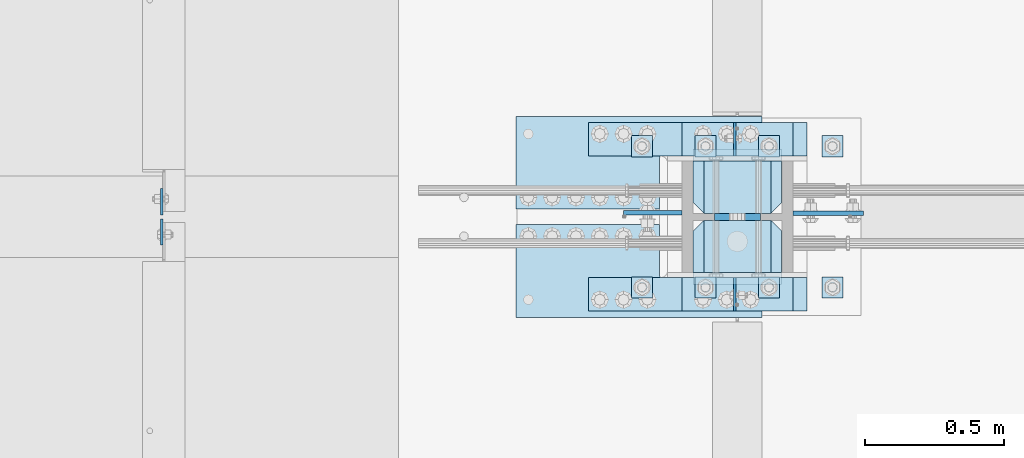
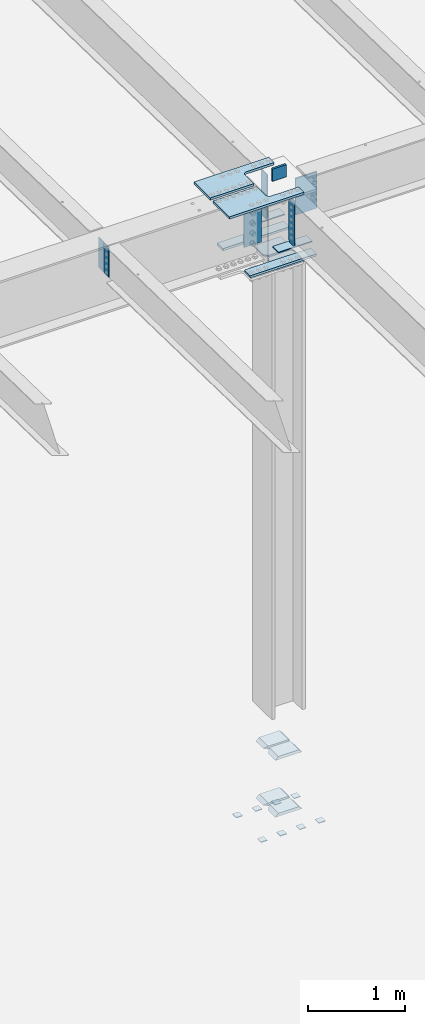
# One storey, part 1492 of 1763: 27 plates, 5 elements without a shape of their own.
"""IFC2X3 building model written with IfcOpenShell, lengths in millimetres."""

import ifcopenshell
import ifcopenshell.guid

model = None  # the IFC model being written
_history = None  # IfcOwnerHistory: only IFC2X3 demands one
_inside = {}  # id of a spatial element -> (the spatial element, [elements in it])
_under = {}  # id of a project, library or spatial element -> (it, [spatial elements below it])
_declared = {}  # id of a project -> (the project, [libraries it declares])
_typed = {}  # id of a type object -> (the type object, [elements of that type])
_made_of = {}  # id of a material, layer set ... -> (it, [elements and type objects made of it])


def new_model(schema):
    """Start an empty IFC model of exactly this schema.

    Asked for "IFC4X3", IfcOpenShell would pick the latest addendum, in which some entities
    have other attributes; the version numbers below select the first issue.
    IFC2X3 requires an IfcOwnerHistory on every rooted entity: one is made here for all.
    """
    global model, _history
    if schema == "IFC4X3":
        model = ifcopenshell.file(schema_version=(4, 3, 0, 0))
    else:
        model = ifcopenshell.file(schema=schema)
    _inside.clear()
    _under.clear()
    _declared.clear()
    _typed.clear()
    _made_of.clear()
    _history = None
    if model.schema == "IFC2X3":
        org = make("IfcOrganization", Name="unknown")
        user = make(
            "IfcPersonAndOrganization",
            ThePerson=make("IfcPerson", FamilyName="unknown"),
            TheOrganization=org,
        )
        app = make(
            "IfcApplication",
            ApplicationDeveloper=org,
            Version="unknown",
            ApplicationFullName="unknown",
            ApplicationIdentifier="unknown",
        )
        _history = make(
            "IfcOwnerHistory",
            OwningUser=user,
            OwningApplication=app,
            ChangeAction="ADDED",
            CreationDate=0,
        )
    return model


def make(cls, **values):
    """One entity of the class cls with the attributes given. An attribute that is None is left unset."""
    return model.create_entity(
        cls, **{name: value for name, value in values.items() if value is not None}
    )


def rooted(cls, **values):
    """An entity with a GlobalId (a new one), such as an element, a storey or a relation."""
    return make(cls, GlobalId=ifcopenshell.guid.new(), OwnerHistory=_history, **values)


def si_unit(unit_type, name, prefix=None):
    """IfcSIUnit, for example si_unit("LENGTHUNIT", "METRE", prefix="MILLI")."""
    return make("IfcSIUnit", UnitType=unit_type, Prefix=prefix, Name=name)


def assignment(units):
    """IfcUnitAssignment: the units of a project."""
    return None if units is None else make("IfcUnitAssignment", Units=units)


def point(xyz):
    """IfcCartesianPoint."""
    return None if xyz is None else make("IfcCartesianPoint", Coordinates=xyz)


def direction(xyz):
    """IfcDirection."""
    return None if xyz is None else make("IfcDirection", DirectionRatios=xyz)


def frame(location, z_axis=None, x_axis=None):
    """IfcAxis2Placement3D, a coordinate frame: its origin and axes. An axis left out is left unset."""
    return make(
        "IfcAxis2Placement3D",
        Location=point(location),
        Axis=direction(z_axis),
        RefDirection=direction(x_axis),
    )


def origin_with_axes():
    """The frame at (0, 0, 0) with the z axis (0, 0, 1) and the x axis (1, 0, 0) written out."""
    return frame((0.0, 0.0, 0.0), z_axis=(0.0, 0.0, 1.0), x_axis=(1.0, 0.0, 0.0))


def place(relative_to, where):
    """IfcLocalPlacement: puts the frame where relative to a parent placement (None: the world)."""
    return make(
        "IfcLocalPlacement", PlacementRelTo=relative_to, RelativePlacement=where
    )


def context(
    kind, dimensions, precision=None, world=None, true_north=None, identifier=None
):
    """IfcGeometricRepresentationContext, for example the 3D "Model" context."""
    return make(
        "IfcGeometricRepresentationContext",
        ContextIdentifier=identifier,
        ContextType=kind,
        CoordinateSpaceDimension=dimensions,
        Precision=precision,
        WorldCoordinateSystem=world,
        TrueNorth=true_north,
    )


def subcontext(parent, identifier, kind, view, scale=None):
    """IfcGeometricRepresentationSubContext, for example "Body" below "Model"."""
    return make(
        "IfcGeometricRepresentationSubContext",
        ContextIdentifier=identifier,
        ContextType=kind,
        ParentContext=parent,
        TargetScale=scale,
        TargetView=view,
    )


def project(units=None, contexts=None):
    """IfcProject with its units and contexts."""
    return rooted(
        "IfcProject",
        Name="project",
        RepresentationContexts=contexts,
        UnitsInContext=assignment(units),
    )


def spatial(cls, under=None, at=None, **own):
    """A site, building, storey or space (cls), placed at a placement, below another one or the project."""
    s = rooted(cls, ObjectPlacement=at, **own)
    if under is not None:
        _under.setdefault(under.id(), (under, []))[1].append(s)
    return s


def faces_of(points, faces, orient=None, outer=None):
    """IfcFace entities. A face is a list of loops; a loop is a list of indices into points, from 0.

    orient and outer hold one flag for each loop. By default every Orientation is true, the
    first loop of a face is its IfcFaceOuterBound and the others are IfcFaceBound.
    """
    made = []
    for i, loops in enumerate(faces):
        bounds = []
        for j, loop in enumerate(loops):
            is_outer = j == 0 if outer is None else outer[i][j]
            bounds.append(
                make(
                    "IfcFaceOuterBound" if is_outer else "IfcFaceBound",
                    Bound=make("IfcPolyLoop", Polygon=[points[k] for k in loop]),
                    Orientation=True if orient is None else orient[i][j],
                )
            )
        made.append(make("IfcFace", Bounds=bounds))
    return made


def faceted_brep(points, faces, orient=None, outer=None, voids=None):
    """IfcFacetedBrep: a solid bounded by flat faces; with voids (closed shells), ...WithVoids."""
    shared = [point(p) for p in points]
    hull = make("IfcClosedShell", CfsFaces=faces_of(shared, faces, orient, outer))
    if voids is None:
        return make("IfcFacetedBrep", Outer=hull)
    return make(
        "IfcFacetedBrepWithVoids",
        Outer=hull,
        Voids=[
            make(cls, CfsFaces=faces_of(shared, fs, o, b)) for cls, fs, o, b in voids
        ],
    )


def shape(context_of_items, identifier, shape_type, items):
    """IfcShapeRepresentation: the items that make up one representation, for example the "Body"."""
    return make(
        "IfcShapeRepresentation",
        ContextOfItems=context_of_items,
        RepresentationIdentifier=identifier,
        RepresentationType=shape_type,
        Items=items,
    )


def material(Name=None, Category=None):
    """IfcMaterial."""
    return make("IfcMaterial", Name=Name, Category=Category)


def made_of(thing, what):
    """Note that an element or type object is made of a material, layer set ...; save() writes the relation."""
    if what is not None:
        _made_of.setdefault(what.id(), (what, []))[1].append(thing)
    return thing


def type_object(cls, material=None, **own):
    """A type object (cls), such as IfcWallType, which elements share."""
    return made_of(rooted(cls, **own), material)


def element(
    cls,
    number,
    at=None,
    inside=None,
    cuts=None,
    type_object=None,
    material=None,
    context=None,
    identifier="Body",
    shape_type=None,
    held_by="IfcProductDefinitionShape",
    body=None,
    shapes=None,
    **own,
):
    """One element of the class cls, such as IfcWall. Its Tag is "e" and its number.

    at: its placement. inside: the storey or other place that contains it. cuts: it is an
    opening in that element (IfcRelVoidsElement). A single representation is given by context,
    identifier, shape_type and body (its items); several are given by shapes. held_by: the class
    of the entity that holds the representations. save() writes the other relations.
    """
    e = rooted(cls, Tag="e%d" % number, ObjectPlacement=at, **own)
    if body is not None:
        shapes = [shape(context, identifier, shape_type, body)]
    if shapes is not None:
        e.Representation = make(held_by, Representations=shapes)
    if inside is not None:
        _inside.setdefault(inside.id(), (inside, []))[1].append(e)
    if cuts is not None:
        rooted(
            "IfcRelVoidsElement", RelatingBuildingElement=cuts, RelatedOpeningElement=e
        )
    if type_object is not None:
        _typed.setdefault(type_object.id(), (type_object, []))[1].append(e)
    return made_of(e, material)


def aggregate(whole, parts):
    """IfcRelAggregates: a whole, such as a stair, and the parts it consists of."""
    return rooted("IfcRelAggregates", RelatingObject=whole, RelatedObjects=parts)


def save(model, path):
    """Write the relations noted so far, then the file.

    IfcRelAggregates (storeys below a building ...), IfcRelContainedInSpatialStructure (elements
    in a storey), IfcRelDefinesByType, IfcRelAssociatesMaterial and IfcRelDeclares: one each for
    every whole, place, type object, material and project.
    """
    for whole, parts in _under.values():
        aggregate(whole, parts)
    for where, things in _inside.values():
        rooted(
            "IfcRelContainedInSpatialStructure",
            RelatedElements=things,
            RelatingStructure=where,
        )
    for kind, things in _typed.values():
        rooted("IfcRelDefinesByType", RelatedObjects=things, RelatingType=kind)
    for what, things in _made_of.values():
        rooted("IfcRelAssociatesMaterial", RelatedObjects=things, RelatingMaterial=what)
    for by, libraries in _declared.values():
        rooted("IfcRelDeclares", RelatingContext=by, RelatedDefinitions=libraries)
    model.write(path)


model = new_model("IFC2X3")

# Units and contexts
model_context = context("Model", 3, precision=1e-05, world=origin_with_axes())
body_context = subcontext(model_context, "Body", "Model", "MODEL_VIEW")
ifc_project = project(units=[si_unit("LENGTHUNIT", "METRE", prefix="MILLI"), si_unit("AREAUNIT", "SQUARE_METRE"), si_unit("VOLUMEUNIT", "CUBIC_METRE"), si_unit("MASSUNIT", "GRAM", prefix="KILO"), si_unit("TIMEUNIT", "SECOND"), si_unit("PLANEANGLEUNIT", "RADIAN"), si_unit("SOLIDANGLEUNIT", "STERADIAN"), si_unit("THERMODYNAMICTEMPERATUREUNIT", "DEGREE_CELSIUS"), si_unit("LUMINOUSINTENSITYUNIT", "LUMEN")], contexts=[model_context])

# Site, building, storey
site_placement = place(None, origin_with_axes())
site = spatial("IfcSite", under=ifc_project, at=site_placement, CompositionType="ELEMENT")
building_placement = place(site_placement, origin_with_axes())
building = spatial("IfcBuilding", under=site, at=building_placement, Name="Undefined", CompositionType="ELEMENT")
storey_placement = place(building_placement, origin_with_axes())
storey = spatial("IfcBuildingStorey", under=building, at=storey_placement, Name="Undefined", CompositionType="ELEMENT", Elevation=0.0)

# Assembly, plates
assembly_1_placement = place(storey_placement, origin_with_axes())
assembly_1 = element("IfcElementAssembly", 1, at=assembly_1_placement, inside=storey, Name="TEMPLATE", AssemblyPlace="NOTDEFINED", PredefinedType="RIGID_FRAME")
ifc_material_1 = material(Name="STEEL/A36")
plate_type_1 = type_object("IfcPlateType", PredefinedType="NOTDEFINED")
plate_1_placement = place(assembly_1_placement, frame((-34645.037273698, 241.299999999951, 3916.3625), z_axis=(0.0, -1.0, 0.0), x_axis=(1.0, 0.0, 0.0)))
plate_1 = element("IfcPlate", 2, at=plate_1_placement, type_object=plate_type_1, material=ifc_material_1, Name="WASHER PLATE", context=body_context, shape_type="Brep", body=[
    faceted_brep([(0.0, -4.76249999999982, 0.0), (0.0, -4.76250000000073, 76.1999969482422), (0.0, 4.76250000000073, 76.1999969482422), (0.0, 4.76249999999982, 0.0), (76.1999969482422, -4.76249999999982, 76.1999969482422), (76.1999969482422, 4.76249999999982, 76.1999969482422), (76.1999969482931, -4.76249999991705, 0.0), (76.1999969482931, 4.76250000006257, 1.81898940354586e-12)], [[[0, 1, 2, 3]], [[1, 4, 5, 2]], [[4, 6, 7, 5]], [[6, 0, 3, 7]], [[5, 7, 3, 2]], [[6, 4, 1, 0]]]),
])
plate_2_placement = place(assembly_1_placement, frame((-34645.037273698, 749.299999999951, 3916.3625), z_axis=(0.0, -1.0, 0.0), x_axis=(1.0, 0.0, 0.0)))
plate_2 = element("IfcPlate", 3, at=plate_2_placement, type_object=plate_type_1, material=ifc_material_1, Name="WASHER PLATE", context=body_context, shape_type="Brep", body=[
    faceted_brep([(0.0, -4.76249999999982, 0.0), (0.0, -4.76250000000073, 76.1999969482422), (0.0, 4.76250000000073, 76.1999969482422), (0.0, 4.76249999999982, 0.0), (76.1999969482422, -4.76249999999982, 76.1999969482422), (76.1999969482422, 4.76249999999982, 76.1999969482422), (76.1999969482931, -4.76249999991705, 0.0), (76.1999969482931, 4.76250000006257, 1.81898940354586e-12)], [[[0, 1, 2, 3]], [[1, 4, 5, 2]], [[4, 6, 7, 5]], [[6, 0, 3, 7]], [[5, 7, 3, 2]], [[6, 4, 1, 0]]]),
])
plate_3_placement = place(assembly_1_placement, frame((-34873.637273698, 241.299999999951, 3916.3625), z_axis=(0.0, -1.0, 0.0), x_axis=(1.0, 0.0, 0.0)))
plate_3 = element("IfcPlate", 4, at=plate_3_placement, type_object=plate_type_1, material=ifc_material_1, Name="WASHER PLATE", context=body_context, shape_type="Brep", body=[
    faceted_brep([(0.0, -4.76249999999982, 0.0), (0.0, -4.76250000000073, 76.1999969482422), (0.0, 4.76250000000073, 76.1999969482422), (0.0, 4.76249999999982, 0.0), (76.1999969482422, -4.76249999999982, 76.1999969482422), (76.1999969482422, 4.76249999999982, 76.1999969482422), (76.1999969482931, -4.76249999991705, 0.0), (76.1999969482931, 4.76250000006257, 1.81898940354586e-12)], [[[0, 1, 2, 3]], [[1, 4, 5, 2]], [[4, 6, 7, 5]], [[6, 0, 3, 7]], [[5, 7, 3, 2]], [[6, 4, 1, 0]]]),
])
plate_4_placement = place(assembly_1_placement, frame((-34873.637273698, 749.299999999951, 3916.3625), z_axis=(0.0, -1.0, 0.0), x_axis=(1.0, 0.0, 0.0)))
plate_4 = element("IfcPlate", 5, at=plate_4_placement, type_object=plate_type_1, material=ifc_material_1, Name="WASHER PLATE", context=body_context, shape_type="Brep", body=[
    faceted_brep([(0.0, -4.76249999999982, 0.0), (0.0, -4.76250000000073, 76.1999969482422), (0.0, 4.76250000000073, 76.1999969482422), (0.0, 4.76249999999982, 0.0), (76.1999969482422, -4.76249999999982, 76.1999969482422), (76.1999969482422, 4.76249999999982, 76.1999969482422), (76.1999969482931, -4.76249999991705, 0.0), (76.1999969482931, 4.76250000006257, 1.81898940354586e-12)], [[[0, 1, 2, 3]], [[1, 4, 5, 2]], [[4, 6, 7, 5]], [[6, 0, 3, 7]], [[5, 7, 3, 2]], [[6, 4, 1, 0]]]),
])
plate_5_placement = place(assembly_1_placement, frame((-35102.237273698, 241.299999999951, 3916.3625), z_axis=(0.0, -1.0, 0.0), x_axis=(1.0, 0.0, 0.0)))
plate_5 = element("IfcPlate", 6, at=plate_5_placement, type_object=plate_type_1, material=ifc_material_1, Name="WASHER PLATE", context=body_context, shape_type="Brep", body=[
    faceted_brep([(0.0, -4.76249999999982, 0.0), (0.0, -4.76250000000073, 76.1999969482422), (0.0, 4.76250000000073, 76.1999969482422), (0.0, 4.76249999999982, 0.0), (76.1999969482422, -4.76249999999982, 76.1999969482422), (76.1999969482422, 4.76249999999982, 76.1999969482422), (76.1999969482931, -4.76249999991705, 0.0), (76.1999969482931, 4.76250000006257, 1.81898940354586e-12)], [[[0, 1, 2, 3]], [[1, 4, 5, 2]], [[4, 6, 7, 5]], [[6, 0, 3, 7]], [[5, 7, 3, 2]], [[6, 4, 1, 0]]]),
])
plate_6_placement = place(assembly_1_placement, frame((-35102.237273698, 749.299999999951, 3916.3625), z_axis=(0.0, -1.0, 0.0), x_axis=(1.0, 0.0, 0.0)))
plate_6 = element("IfcPlate", 7, at=plate_6_placement, type_object=plate_type_1, material=ifc_material_1, Name="WASHER PLATE", context=body_context, shape_type="Brep", body=[
    faceted_brep([(0.0, -4.76249999999982, 0.0), (0.0, -4.76250000000073, 76.1999969482422), (0.0, 4.76250000000073, 76.1999969482422), (0.0, 4.76249999999982, 0.0), (76.1999969482422, -4.76249999999982, 76.1999969482422), (76.1999969482422, 4.76249999999982, 76.1999969482422), (76.1999969482931, -4.76249999991705, 0.0), (76.1999969482931, 4.76250000006257, 1.81898940354586e-12)], [[[0, 1, 2, 3]], [[1, 4, 5, 2]], [[4, 6, 7, 5]], [[6, 0, 3, 7]], [[5, 7, 3, 2]], [[6, 4, 1, 0]]]),
])
plate_7_placement = place(assembly_1_placement, frame((-35330.837273698, 241.299999999951, 3916.3625), z_axis=(0.0, -1.0, 0.0), x_axis=(1.0, 0.0, 0.0)))
plate_7 = element("IfcPlate", 8, at=plate_7_placement, type_object=plate_type_1, material=ifc_material_1, Name="WASHER PLATE", context=body_context, shape_type="Brep", body=[
    faceted_brep([(0.0, -4.76249999999982, 0.0), (0.0, -4.76250000000073, 76.1999969482422), (0.0, 4.76250000000073, 76.1999969482422), (0.0, 4.76249999999982, 0.0), (76.1999969482422, -4.76249999999982, 76.1999969482422), (76.1999969482422, 4.76249999999982, 76.1999969482422), (76.1999969482931, -4.76249999991705, 0.0), (76.1999969482931, 4.76250000006257, 1.81898940354586e-12)], [[[0, 1, 2, 3]], [[1, 4, 5, 2]], [[4, 6, 7, 5]], [[6, 0, 3, 7]], [[5, 7, 3, 2]], [[6, 4, 1, 0]]]),
])
plate_8_placement = place(assembly_1_placement, frame((-35330.837273698, 749.299999999951, 3916.3625), z_axis=(0.0, -1.0, 0.0), x_axis=(1.0, 0.0, 0.0)))
plate_8 = element("IfcPlate", 9, at=plate_8_placement, type_object=plate_type_1, material=ifc_material_1, Name="WASHER PLATE", context=body_context, shape_type="Brep", body=[
    faceted_brep([(0.0, -4.76249999999982, 0.0), (0.0, -4.76250000000073, 76.1999969482422), (0.0, 4.76250000000073, 76.1999969482422), (0.0, 4.76249999999982, 0.0), (76.1999969482422, -4.76249999999982, 76.1999969482422), (76.1999969482422, 4.76249999999982, 76.1999969482422), (76.1999969482931, -4.76249999991705, 0.0), (76.1999969482931, 4.76250000006257, 1.81898940354586e-12)], [[[0, 1, 2, 3]], [[1, 4, 5, 2]], [[4, 6, 7, 5]], [[6, 0, 3, 7]], [[5, 7, 3, 2]], [[6, 4, 1, 0]]]),
])
aggregate(assembly_1, [plate_1, plate_2, plate_3, plate_4, plate_5, plate_6, plate_7, plate_8])

assembly_2_placement = place(storey_placement, origin_with_axes())
assembly_2 = element("IfcElementAssembly", 10, at=assembly_2_placement, inside=storey, Name="COLUMN", AssemblyPlace="NOTDEFINED", PredefinedType="RIGID_FRAME")
plate_type_2 = type_object("IfcPlateType", PredefinedType="NOTDEFINED")
plate_9_placement = place(assembly_2_placement, frame((-34791.087273698, 257.174999999951, 4826.0), z_axis=(-1.0, 0.0, 0.0), x_axis=(0.0, 1.0, 0.0)))
plate_9 = element("IfcPlate", 11, at=plate_9_placement, type_object=plate_type_2, material=ifc_material_1, Name="PLATE", context=body_context, shape_type="Brep", body=[
    faceted_brep([(187.324996948242, -19.0500000000002, 279.400001525879), (149.224998474121, 19.0500000000002, 317.5), (-1.13686837721616e-13, 19.0500000000002, 317.5), (-1.13686837721616e-13, -19.0500000000002, 279.400000002177), (187.324996948242, -19.0500000000002, 38.0999984741211), (0.0, -19.0500000000002, 38.099999997823), (0.0, 19.0500000000029, 0.0), (149.224998474121, 19.0500000000002, 0.0), (187.324996948242, 19.0500000000002, 38.0999984741211), (187.324996948242, 19.0500000000002, 279.400001525879)], [[[0, 1, 2, 3]], [[4, 5, 6, 7]], [[8, 4, 7]], [[0, 4, 8, 9]], [[5, 4, 0, 3]], [[6, 5, 3, 2]], [[9, 8, 7, 6, 2, 1]], [[9, 1, 0]]]),
])
plate_10_placement = place(assembly_2_placement, frame((-34791.087273698, 469.899999999951, 4826.0), z_axis=(-1.0, 0.0, 0.0), x_axis=(0.0, 1.0, 0.0)))
plate_10 = element("IfcPlate", 12, at=plate_10_placement, type_object=plate_type_2, material=ifc_material_1, Name="PLATE", context=body_context, shape_type="Brep", body=[
    faceted_brep([(187.324996948242, -19.0500000000002, 38.0999984741211), (0.0, -19.0500000000002, 38.099999997823), (38.0999984741211, 19.0500000000002, 0.0), (187.324996948242, 19.0500000000002, 0.0), (0.0, 19.0500000000002, 38.0999984741211), (0.0, 19.0500000000002, 279.400001525879), (-1.13686837721616e-13, -19.0500000000002, 279.400000002177), (38.0999984741211, 19.0500000000002, 317.5), (187.324996948242, 19.0500000000002, 317.5), (187.324996948242, -19.0500000000002, 279.400001525879)], [[[0, 1, 2, 3]], [[4, 2, 1]], [[5, 6, 7]], [[8, 7, 6, 9]], [[8, 9, 0, 3]], [[4, 5, 7, 8, 3, 2]], [[1, 6, 5, 4]], [[1, 0, 9, 6]]]),
])
plate_11_placement = place(assembly_2_placement, frame((-34791.087273698, 257.174999999951, 4114.8), z_axis=(-1.0, 0.0, 0.0), x_axis=(0.0, 1.0, 0.0)))
plate_11 = element("IfcPlate", 13, at=plate_11_placement, type_object=plate_type_2, material=ifc_material_1, Name="PLATE", context=body_context, shape_type="Brep", body=[
    faceted_brep([(187.324996948242, -19.0500000000002, 279.400001525879), (149.224998474121, 19.0500000000002, 317.5), (-1.13686837721616e-13, 19.0500000000002, 317.5), (-1.13686837721616e-13, -19.0500000000002, 279.400000002177), (187.324996948242, -19.0500000000002, 38.0999984741211), (0.0, -19.0500000000002, 38.099999997823), (0.0, 19.0500000000029, 0.0), (149.224998474121, 19.0500000000002, 0.0), (187.324996948242, 19.0500000000002, 38.0999984741211), (187.324996948242, 19.0500000000002, 279.400001525879)], [[[0, 1, 2, 3]], [[4, 5, 6, 7]], [[8, 4, 7]], [[0, 4, 8, 9]], [[5, 4, 0, 3]], [[6, 5, 3, 2]], [[9, 8, 7, 6, 2, 1]], [[9, 1, 0]]]),
])
plate_12_placement = place(assembly_2_placement, frame((-34791.087273698, 469.899999999951, 4114.8), z_axis=(-1.0, 0.0, 0.0), x_axis=(0.0, 1.0, 0.0)))
plate_12 = element("IfcPlate", 14, at=plate_12_placement, type_object=plate_type_2, material=ifc_material_1, Name="PLATE", context=body_context, shape_type="Brep", body=[
    faceted_brep([(187.324996948242, -19.0500000000002, 38.0999984741211), (0.0, -19.0500000000002, 38.099999997823), (38.0999984741211, 19.0500000000002, 0.0), (187.324996948242, 19.0500000000002, 0.0), (0.0, 19.0500000000002, 38.0999984741211), (0.0, 19.0500000000002, 279.400001525879), (-1.13686837721616e-13, -19.0500000000002, 279.400000002177), (38.0999984741211, 19.0500000000002, 317.5), (187.324996948242, 19.0500000000002, 317.5), (187.324996948242, -19.0500000000002, 279.400001525879)], [[[0, 1, 2, 3]], [[4, 2, 1]], [[5, 6, 7]], [[8, 7, 6, 9]], [[8, 9, 0, 3]], [[4, 5, 7, 8, 3, 2]], [[1, 6, 5, 4]], [[1, 0, 9, 6]]]),
])
plate_type_3 = type_object("IfcPlateType", PredefinedType="NOTDEFINED")
plate_13_placement = place(assembly_2_placement, frame((-34959.361773782, 238.125018107547, 11850.7814630201), z_axis=(0.0, -1.0, 0.0), x_axis=(0.0, 0.0, -1.0)))
plate_13 = element("IfcPlate", 15, at=plate_13_placement, type_object=plate_type_3, material=ifc_material_1, Name="PLATE", context=body_context, shape_type="Brep", body=[
    faceted_brep([(576.262512472324, -4.76249999999709, 25.399999887427), (550.862512588501, -4.76249999999709, -4.00945054934709e-10), (550.862512588501, 4.76249999999709, -4.00945054934709e-10), (576.262512207044, 4.76249999999709, 25.399999887427), (0.0, -4.76249999999982, 0.0), (3.8198777474463e-11, -4.76249999978609, 120.649999999834), (3.45607986673713e-11, 4.76250000024447, 120.649999999841), (0.0, 4.76249999999982, 0.0), (576.262512207095, -4.76249999999709, 120.650001525885), (576.262512207095, 4.76249999999709, 120.650001525885)], [[[0, 1, 2, 3]], [[4, 5, 6, 7]], [[5, 8, 9, 6]], [[9, 8, 0, 3]], [[7, 6, 9, 3, 2]], [[4, 7, 2, 1]], [[8, 5, 4, 1, 0]]]),
])
plate_14_placement = place(assembly_2_placement, frame((-34959.3617737819, 676.274999714254, 11838.9664806447), z_axis=(0.0, 1.0, 0.0), x_axis=(0.0, 0.0, -1.0)))
plate_14 = element("IfcPlate", 16, at=plate_14_placement, type_object=plate_type_3, material=ifc_material_1, Name="PLATE", context=body_context, shape_type="Brep", body=[
    faceted_brep([(565.15002468296, -4.76249999999709, 25.3999998837656), (539.750024795532, -4.76249999999709, 3.46858541888651e-10), (539.750024795532, 4.76249999999709, 3.46858541888651e-10), (565.150024414048, 4.76249999999709, 25.3999998837656), (0.0, -4.76249999999982, 0.0), (3.8198777474463e-11, -4.76249999978609, 120.649999999834), (3.45607986673713e-11, 4.76250000024447, 120.649999999841), (0.0, 4.76249999999982, 0.0), (565.150024413999, -4.76249999999709, 120.650001525857), (565.150024413999, 4.76249999999709, 120.650001525857)], [[[0, 1, 2, 3]], [[4, 5, 6, 7]], [[5, 8, 9, 6]], [[9, 8, 0, 3]], [[7, 6, 9, 3, 2]], [[4, 7, 2, 1]], [[8, 5, 4, 1, 0]]]),
])
ifc_material_2 = material(Name="STEEL/A572-50")
plate_type_4 = type_object("IfcPlateType", PredefinedType="NOTDEFINED")
plate_15_placement = place(assembly_2_placement, frame((-34867.2872721725, 457.200000000004, 12073.4961653918), z_axis=(0.0, 0.0, -1.0), x_axis=(-1.0, 0.0, 0.0)))
plate_15 = element("IfcPlate", 17, at=plate_15_placement, type_object=plate_type_4, material=ifc_material_2, Name="PLATE", context=body_context, shape_type="Brep", body=[
    faceted_brep([(0.0, 12.7, 152.399990844726), (-1.45519152283669e-11, 7.27595761418343e-12, 165.099990844727), (165.099990844727, 0.0, 165.099990844727), (165.099990844727, 12.7, 152.399990844726), (0.0, -12.7, 152.399990844726), (165.099990844727, -12.7, 152.399990844726), (0.0, 12.6999999999971, -1.81898940354586e-12), (0.0, -12.6999999999971, -1.81898940354586e-12), (165.099990844727, -12.7, 0.0), (165.099990844727, 12.7, 0.0)], [[[0, 1, 2, 3]], [[1, 4, 5, 2]], [[6, 7, 4, 1, 0]], [[5, 8, 9, 3, 2]], [[8, 7, 6, 9]], [[9, 6, 0, 3]], [[7, 8, 5, 4]]]),
])

assembly_3_placement = place(storey_placement, origin_with_axes())
assembly_3 = element("IfcElementAssembly", 18, at=assembly_3_placement, inside=storey, Name="BEAM", AssemblyPlace="NOTDEFINED", PredefinedType="RIGID_FRAME")
plate_type_5 = type_object("IfcPlateType", PredefinedType="NOTDEFINED")
plate_16_placement = place(assembly_3_placement, frame((-37022.4321665555, 450.056250000003, 11850.9816334535), z_axis=(0.0, -1.0, 0.0), x_axis=(0.0, 0.0, -1.0)))
plate_16 = element("IfcPlate", 19, at=plate_16_placement, type_object=plate_type_5, material=ifc_material_1, Name="PLATE", context=body_context, shape_type="Brep", body=[
    faceted_brep([(0.0, -3.96900000000096, 0.0), (0.0, -3.96900000000096, 95.25), (0.0, 3.96900000000096, 95.25), (0.0, 3.96900000000096, 0.0), (381.0, -3.96899999999732, 95.25), (381.0, 3.96899999999732, 95.25), (381.0, -3.96900000001915, 3.34694050252438e-10), (381.0, 3.9690000000046, 3.20142135024071e-10)], [[[0, 1, 2, 3]], [[1, 4, 5, 2]], [[4, 6, 7, 5]], [[6, 0, 3, 7]], [[5, 7, 3, 2]], [[6, 4, 1, 0]]]),
])
plate_17_placement = place(assembly_3_placement, frame((-37022.4321665555, 464.343750000004, 11851.4690855874), z_axis=(0.0, 1.0, 0.0), x_axis=(0.0, 0.0, -1.0)))
plate_17 = element("IfcPlate", 20, at=plate_17_placement, type_object=plate_type_5, material=ifc_material_1, Name="PLATE", context=body_context, shape_type="Brep", body=[
    faceted_brep([(0.0, -3.96900000000096, 0.0), (0.0, -3.96900000000096, 95.25), (0.0, 3.96900000000096, 95.25), (0.0, 3.96900000000096, 0.0), (381.0, -3.96899999999732, 95.25), (381.0, 3.96899999999732, 95.25), (381.0, -3.96900000001915, 3.34694050252438e-10), (381.0, 3.9690000000046, 3.20142135024071e-10)], [[[0, 1, 2, 3]], [[1, 4, 5, 2]], [[4, 6, 7, 5]], [[6, 0, 3, 7]], [[5, 7, 3, 2]], [[6, 4, 1, 0]]]),
])
aggregate(assembly_3, [plate_16, plate_17])

# Plate
plate_type_6 = type_object("IfcPlateType", PredefinedType="NOTDEFINED")
plate_18_placement = place(assembly_2_placement, frame((-35149.8622923235, 796.924982022941, 11267.0461663645), z_axis=(1.0, 0.0, 0.0), x_axis=(0.0, -1.0, 0.0)))
plate_18 = element("IfcPlate", 21, at=plate_18_placement, type_object=plate_type_6, material=ifc_material_2, Name="PLATE", context=body_context, shape_type="Brep", body=[
    faceted_brep([(0.0, -6.34999999999491, 1.45519152283669e-11), (-1.99297119252151e-05, -6.34999999990214, 400.04998779294), (-1.99297119252151e-05, 6.35000000009677, 400.049987792983), (0.0, 6.34999999999491, -2.91038304567337e-11), (120.64998626709, -6.34999999990214, 400.04998779294), (120.64998626709, 6.35000000009677, 400.049987792983), (120.650001525879, -6.350000000004, -2.91038304567337e-11), (120.650001525879, 6.34999999999673, 1.45519152283669e-11)], [[[0, 1, 2, 3]], [[1, 4, 5, 2]], [[4, 6, 7, 5]], [[6, 0, 3, 7]], [[5, 7, 3, 2]], [[6, 4, 1, 0]]]),
])

plate_19_placement = place(assembly_2_placement, frame((-35149.8622923235, 238.124992199073, 11267.0461702762), z_axis=(1.0, 0.0, 0.0), x_axis=(0.0, -1.0, 0.0)))
plate_19 = element("IfcPlate", 22, at=plate_19_placement, type_object=plate_type_6, material=ifc_material_2, Name="PLATE", context=body_context, shape_type="Brep", body=[
    faceted_brep([(0.0, -6.34999999999491, 1.45519152283669e-11), (-1.99297119252151e-05, -6.34999999990214, 400.04998779294), (-1.99297119252151e-05, 6.35000000009677, 400.049987792983), (0.0, 6.34999999999491, -2.91038304567337e-11), (120.64998626709, -6.34999999990214, 400.04998779294), (120.64998626709, 6.35000000009677, 400.049987792983), (120.650001525879, -6.350000000004, -2.91038304567337e-11), (120.650001525879, 6.34999999999673, 1.45519152283669e-11)], [[[0, 1, 2, 3]], [[1, 4, 5, 2]], [[4, 6, 7, 5]], [[6, 0, 3, 7]], [[5, 7, 3, 2]], [[6, 4, 1, 0]]]),
])

plate_type_7 = type_object("IfcPlateType", PredefinedType="NOTDEFINED")
plate_20_placement = place(assembly_2_placement, frame((-34749.812273698, 470.693750000001, 11844.8961714953), z_axis=(1.0, 0.0, 0.0), x_axis=(0.0, 0.0, -1.0)))
plate_20 = element("IfcPlate", 23, at=plate_20_placement, type_object=plate_type_7, material=ifc_material_2, Name="PLATE", context=body_context, shape_type="Brep", body=[
    faceted_brep([(-7.27595761418343e-12, -7.9375, 0.0), (0.0, -7.9375, 254.0), (0.0, 7.9375, 254.0), (-7.27595761418343e-12, 7.9375, 0.0), (457.200012207031, -7.9375, 254.0), (457.200012207031, 7.9375, 254.0), (457.200012207031, -7.9375, 0.0), (457.200012207031, 7.9375, 0.0)], [[[0, 1, 2, 3]], [[1, 4, 5, 2]], [[4, 6, 7, 5]], [[6, 0, 3, 7]], [[5, 7, 3, 2]], [[6, 4, 1, 0]]]),
])

plate_type_8 = type_object("IfcPlateType", PredefinedType="NOTDEFINED")
plate_21_placement = place(assembly_2_placement, frame((-34791.087273698, 212.724999999951, 10981.2961354907), z_axis=(-1.0, 0.0, 0.0), x_axis=(0.0, 1.0, 0.0)))
plate_21 = element("IfcPlate", 24, at=plate_21_placement, type_object=plate_type_8, material=ifc_material_2, Name="PLATE", context=body_context, shape_type="Brep", body=[
    faceted_brep([(0.0, -9.52500000000146, 0.0), (-5.6843418860808e-14, -9.52499999999964, 317.5), (-5.6843418860808e-14, 9.52499999999964, 317.5), (0.0, 9.52500000000146, 0.0), (193.674995422363, -9.52499999999964, 317.5), (193.674995422363, 9.52499999999964, 317.5), (231.774993896484, -9.52499999999964, 279.400001525879), (231.774993896484, 9.52499999999964, 279.400001525879), (231.774993896484, -9.52499999999964, 38.0999984741211), (231.774993896484, 9.52499999999964, 38.0999984741211), (193.674995422363, -9.52499999999964, 0.0), (193.674995422363, 9.52499999999964, 0.0)], [[[0, 1, 2, 3]], [[1, 4, 5, 2]], [[4, 6, 7, 5]], [[6, 8, 9, 7]], [[8, 10, 11, 9]], [[10, 0, 3, 11]], [[5, 7, 9, 11, 3, 2]], [[10, 8, 6, 4, 1, 0]]]),
])

plate_22_placement = place(assembly_2_placement, frame((-34791.087273698, 469.899999999951, 10981.2961354907), z_axis=(-1.0, 0.0, 0.0), x_axis=(0.0, 1.0, 0.0)))
plate_22 = element("IfcPlate", 25, at=plate_22_placement, type_object=plate_type_8, material=ifc_material_2, Name="PLATE", context=body_context, shape_type="Brep", body=[
    faceted_brep([(0.0, -9.52500000000146, 38.0999984741211), (0.0, -9.52499999999964, 279.400001525879), (0.0, 9.52499999999964, 279.400001525879), (0.0, 9.52500000000146, 38.0999984741211), (38.0999984741211, -9.52499999999964, 317.5), (38.0999984741211, 9.52499999999964, 317.5), (231.774993896484, -9.52499999999964, 317.5), (231.774993896484, 9.52499999999964, 317.5), (231.774993896484, -9.52499999999964, 0.0), (231.774993896484, 9.52499999999964, 0.0), (38.0999984741211, -9.52500000000146, 0.0), (38.0999984741211, 9.52500000000146, 0.0)], [[[0, 1, 2, 3]], [[1, 4, 5, 2]], [[4, 6, 7, 5]], [[6, 8, 9, 7]], [[8, 10, 11, 9]], [[10, 0, 3, 11]], [[5, 7, 9, 11, 3, 2]], [[10, 8, 6, 4, 1, 0]]]),
])

plate_type_9 = type_object("IfcPlateType", PredefinedType="NOTDEFINED")
plate_23_placement = place(assembly_2_placement, frame((-35149.862273698, 472.281250000003, 11782.9836714953), z_axis=(-1.0, 0.0, 0.0), x_axis=(0.0, 0.0, -1.0)))
plate_23 = element("IfcPlate", 26, at=plate_23_placement, type_object=plate_type_9, material=ifc_material_2, Name="PLATE", context=body_context, shape_type="Brep", body=[
    faceted_brep([(-7.27595761418343e-12, -7.9375, 0.0), (0.0, -7.9375, 209.550003051758), (0.0, 7.9375, 209.550003051758), (-7.27595761418343e-12, 7.9375, 0.0), (590.549987792969, -7.9375, 209.550003051758), (590.549987792969, 7.9375, 209.550003051758), (590.549987792969, -7.9375, 0.0), (590.549987792969, 7.9375, 0.0)], [[[0, 1, 2, 3]], [[1, 4, 5, 2]], [[4, 6, 7, 5]], [[6, 0, 3, 7]], [[5, 7, 3, 2]], [[6, 4, 1, 0]]]),
])

# Assembly, plate
assembly_4_placement = place(storey_placement, origin_with_axes())
assembly_4 = element("IfcElementAssembly", 27, at=assembly_4_placement, inside=storey, Name="PLATE", AssemblyPlace="NOTDEFINED", PredefinedType="RIGID_FRAME")
plate_type_10 = type_object("IfcPlateType", PredefinedType="NOTDEFINED")
plate_24_placement = place(assembly_4_placement, frame((-34860.8721173118, 485.774971362443, 11922.6836719243), z_axis=(-1.0, 0.0, 0.0), x_axis=(0.0, 1.0, 0.0)))
plate_24 = element("IfcPlate", 28, at=plate_24_placement, type_object=plate_type_10, material=ifc_material_2, Name="PLATE", context=body_context, shape_type="Brep", body=[
    faceted_brep([(-7.9960619814301e-07, -14.287499999853, 368.299988574778), (-7.9960619814301e-07, 14.2875000001459, 368.299988689221), (184.150001157359, 14.2875000001459, 368.299988873921), (184.150001157359, -14.287499999853, 368.299988759471), (195.923548173387, 14.2875000001459, 366.435242231251), (195.923548173387, -14.287499999853, 366.435242116808), (206.544618380093, 14.2875000001459, 361.023536673485), (206.544618380093, -14.2874999998548, 361.023536559042), (214.973547424297, 14.2875000001404, 352.594607646162), (214.973547424297, -14.2874999998585, 352.594607531719), (220.385253003348, 14.2875000001368, 341.973537450307), (220.385253003348, -14.2874999998639, 341.973537335856), (222.249999669601, -14.2874999998676, 330.19999032357), (222.249999669601, 14.2875000001332, 330.199990438014), (222.24999999999, 14.2875000000004, -1.01863406598568e-10), (222.24999999999, -14.2875000000004, -1.45519152283669e-10), (-1.92324472436667e-06, -14.2874999996457, 885.849853515603), (333.37499999999, -14.2874999996457, 885.849853515414), (333.37499999999, 14.2875000003551, 885.849853515458), (-1.92324472436667e-06, 14.2875000003551, 885.84985351564), (333.375030517578, -14.2875000000004, -2.03726813197136e-10), (333.375030517578, 14.2875000000004, -1.60071067512035e-10)], [[[0, 1, 2, 3]], [[3, 2, 4, 5]], [[5, 4, 6, 7]], [[7, 6, 8, 9]], [[9, 8, 10, 11]], [[12, 13, 14, 15]], [[11, 10, 13, 12]], [[16, 17, 18, 19]], [[17, 20, 21, 18]], [[21, 20, 15, 14]], [[8, 6, 4, 2, 1, 19, 18, 21, 14, 13, 10]], [[16, 19, 1, 0]], [[20, 17, 16, 0, 3, 5, 7, 9, 11, 12, 15]]]),
])
aggregate(assembly_4, [plate_24])

assembly_5_placement = place(storey_placement, origin_with_axes())
assembly_5 = element("IfcElementAssembly", 29, at=assembly_5_placement, inside=storey, Name="PLATE", AssemblyPlace="NOTDEFINED", PredefinedType="RIGID_FRAME")
plate_25_placement = place(assembly_5_placement, frame((-34860.8721181342, 428.625029347538, 11922.6836719243), z_axis=(-1.0, 0.0, 0.0), x_axis=(0.0, -1.0, 0.0)))
plate_25 = element("IfcPlate", 30, at=plate_25_placement, type_object=plate_type_10, material=ifc_material_2, Name="PLATE", context=body_context, shape_type="Brep", body=[
    faceted_brep([(-7.9960619814301e-07, -14.287499999853, 368.299988574778), (-7.9960619814301e-07, 14.2875000001459, 368.299988689221), (184.150001157359, 14.2875000001459, 368.299988873921), (184.150001157359, -14.287499999853, 368.299988759471), (195.923548173387, 14.2875000001459, 366.435242231251), (195.923548173387, -14.287499999853, 366.435242116808), (206.544618380093, 14.2875000001459, 361.023536673485), (206.544618380093, -14.2874999998548, 361.023536559042), (214.973547424297, 14.2875000001404, 352.594607646162), (214.973547424297, -14.2874999998585, 352.594607531719), (220.385253003348, 14.2875000001368, 341.973537450307), (220.385253003348, -14.2874999998639, 341.973537335856), (222.249999669601, -14.2874999998676, 330.19999032357), (222.249999669601, 14.2875000001332, 330.199990438014), (222.24999999999, 14.2875000000004, -1.01863406598568e-10), (222.24999999999, -14.2875000000004, -1.45519152283669e-10), (-1.92324472436667e-06, -14.2874999996457, 885.849853515603), (333.37499999999, -14.2874999996457, 885.849853515414), (333.37499999999, 14.2875000003551, 885.849853515458), (-1.92324472436667e-06, 14.2875000003551, 885.84985351564), (333.375030517578, -14.2875000000004, -2.03726813197136e-10), (333.375030517578, 14.2875000000004, -1.60071067512035e-10)], [[[0, 1, 2, 3]], [[3, 2, 4, 5]], [[5, 4, 6, 7]], [[7, 6, 8, 9]], [[9, 8, 10, 11]], [[12, 13, 14, 15]], [[11, 10, 13, 12]], [[16, 17, 18, 19]], [[17, 20, 21, 18]], [[21, 20, 15, 14]], [[8, 6, 4, 2, 1, 19, 18, 21, 14, 13, 10]], [[16, 19, 1, 0]], [[20, 17, 16, 0, 3, 5, 7, 9, 11, 12, 15]]]),
])
aggregate(assembly_5, [plate_25])

# Plate
plate_type_11 = type_object("IfcPlateType", PredefinedType="NOTDEFINED")
plate_26_placement = place(assembly_2_placement, frame((-34698.947082531, 676.274981688605, 11081.3086714953), z_axis=(-1.0, 0.0, 0.0), x_axis=(0.0, 1.0, 0.0)))
plate_26 = element("IfcPlate", 31, at=plate_26_placement, type_object=plate_type_11, material=ifc_material_2, Name="PLATE", context=body_context, shape_type="Brep", body=[
    faceted_brep([(0.0, -14.2875000000058, 0.0), (-3.66389258488198e-07, -14.2875000006989, 787.41003417968), (-3.66389258488198e-07, 14.2874999993019, 787.410034179702), (0.0, 14.2875000000058, 0.0), (120.649988524181, -14.2875000006989, 787.41003417968), (120.649988524181, 14.2874999993019, 787.410034179702), (120.650001525879, -14.2875000000004, 0.0), (120.650001525879, 14.2875000000004, 0.0)], [[[0, 1, 2, 3]], [[2, 1, 4, 5]], [[4, 6, 7, 5]], [[6, 0, 3, 7]], [[5, 7, 3, 2]], [[6, 4, 1, 0]]]),
])

plate_27_placement = place(assembly_2_placement, frame((-34698.947082531, 238.125018311395, 11081.3086714953), z_axis=(-1.0, 0.0, 0.0), x_axis=(0.0, -1.0, 0.0)))
plate_27 = element("IfcPlate", 32, at=plate_27_placement, type_object=plate_type_11, material=ifc_material_2, Name="PLATE", context=body_context, shape_type="Brep", body=[
    faceted_brep([(0.0, -14.2875000000058, 0.0), (-3.66389258488198e-07, -14.2875000006989, 787.41003417968), (-3.66389258488198e-07, 14.2874999993019, 787.410034179702), (0.0, 14.2875000000058, 0.0), (120.649988524181, -14.2875000006989, 787.41003417968), (120.649988524181, 14.2874999993019, 787.410034179702), (120.650001525879, -14.2875000000004, 0.0), (120.650001525879, 14.2875000000004, 0.0)], [[[0, 1, 2, 3]], [[2, 1, 4, 5]], [[4, 6, 7, 5]], [[6, 0, 3, 7]], [[5, 7, 3, 2]], [[6, 4, 1, 0]]]),
])

aggregate(assembly_2, [plate_9, plate_10, plate_11, plate_12, plate_18, plate_19, plate_15, plate_21, plate_22, plate_13, plate_14, plate_23, plate_20, plate_26, plate_27])

save(model, "model.ifc")
